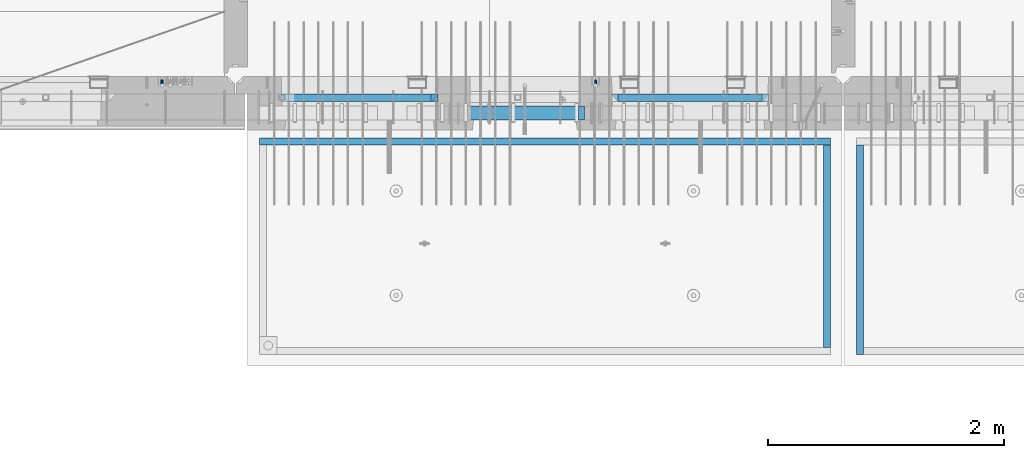
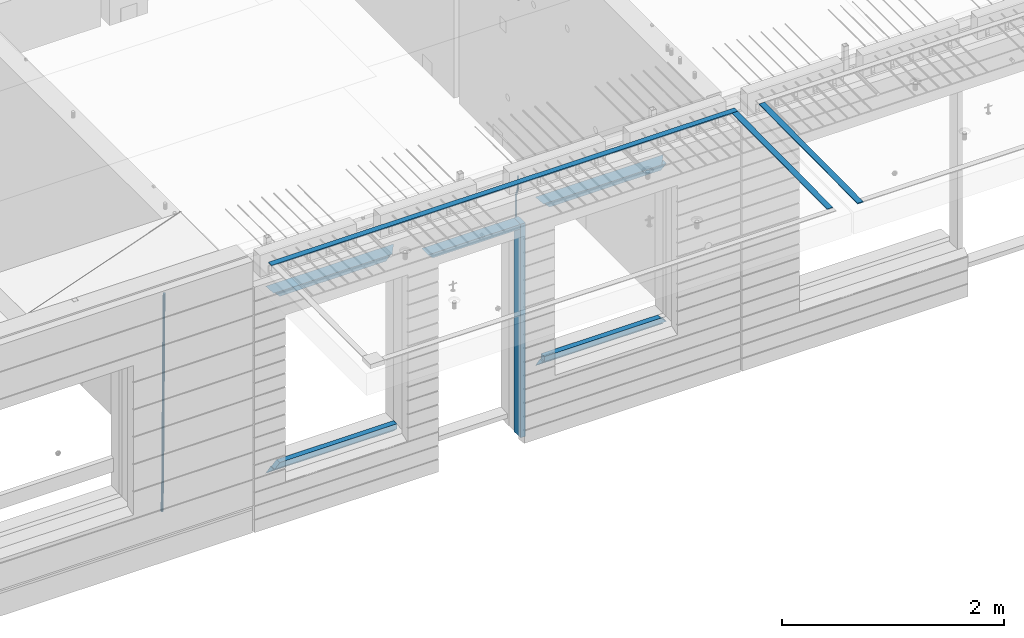
# One storey, part 96 of 350: 15 beams, 4 elements without a shape of their own.
"""IFC2X3 building model written with IfcOpenShell, lengths in millimetres."""

from ifc_helpers import new_model, si_unit, frame, origin_with_axes, place, context, subcontext, project, spatial, faceted_brep, material, type_object, element, aggregate, save


model = new_model("IFC2X3")

# Units and contexts
model_context = context("Model", 3, precision=1e-05, world=origin_with_axes())
body_context = subcontext(model_context, "Body", "Model", "MODEL_VIEW")
ifc_project = project(units=[si_unit("LENGTHUNIT", "METRE", prefix="MILLI"), si_unit("AREAUNIT", "SQUARE_METRE"), si_unit("VOLUMEUNIT", "CUBIC_METRE"), si_unit("MASSUNIT", "GRAM", prefix="KILO"), si_unit("TIMEUNIT", "SECOND"), si_unit("PLANEANGLEUNIT", "RADIAN"), si_unit("SOLIDANGLEUNIT", "STERADIAN"), si_unit("THERMODYNAMICTEMPERATUREUNIT", "DEGREE_CELSIUS"), si_unit("LUMINOUSINTENSITYUNIT", "LUMEN")], contexts=[model_context])

# Site, building, storey
site_placement = place(None, origin_with_axes())
site = spatial("IfcSite", under=ifc_project, at=site_placement, CompositionType="ELEMENT")
building_placement = place(site_placement, origin_with_axes())
building = spatial("IfcBuilding", under=site, at=building_placement, CompositionType="ELEMENT")
storey_placement = place(building_placement, origin_with_axes())
storey = spatial("IfcBuildingStorey", under=building, at=storey_placement, Name="2", CompositionType="ELEMENT", Elevation=0.0)

# Assembly, beam
assembly_1_placement = place(storey_placement, origin_with_axes())
assembly_1 = element("IfcElementAssembly", 1, at=assembly_1_placement, inside=storey, AssemblyPlace="NOTDEFINED", PredefinedType="REINFORCEMENT_UNIT")
ifc_material_1 = material()
beam_type_1 = type_object("IfcBeamType", Name="D20", PredefinedType="NOTDEFINED")
beam_1_placement = place(assembly_1_placement, frame((19710.0073333522, 7925.0, 87407.5000058722), z_axis=(0.000415599999849905, 0.999999913638203, 4.76000000899737e-07), x_axis=(0.0, 0.0, -1.0)))
beam_1 = element("IfcBeam", 2, at=beam_1_placement, type_object=beam_type_1, material=ifc_material_1, Name="JM20", ObjectType="D20", context=body_context, shape_type="Brep", body=[
    faceted_brep([(0.0, -10.0, 0.0), (-4.19531716033816e-08, -7.07106781186667, -7.07106781187031), (113.248091332178, -7.0710684840451, -7.0710678117357), (113.248091314759, -10.0000006713562, -2.51020537689328e-10), (0.0, 0.0, -10.0), (113.248091374131, -6.72178430249915e-07, -9.99999999986903), (4.196772351861e-08, 7.07106781186303, -7.07106781186667), (113.248091416113, 7.07106713968824, -7.07106781173934), (0.0, 10.0, 0.0), (113.248091433488, 9.99999932782521, 1.30967237055302e-10), (4.196772351861e-08, 7.07106781185939, 7.07106781185939), (113.248091416113, 7.0710671396846, 7.071067811994), (0.0, 0.0, 10.0), (113.248091374131, -6.72174792271107e-07, 10.0000000001273), (-4.19531716033816e-08, -7.07106781187031, 7.07106781185939), (113.248091332178, -7.0710684840451, 7.071067811994), (130.699843527167, -7.06993249763036, -4.33745683788584), (128.538066582521, -9.99900540317321, 2.39499413731755), (131.594536475241, 0.00119355250353692, -7.12624594330919), (130.698046432328, 7.07220300913468, -4.33773834422391), (128.535525107087, 10.0009944322555, 2.39459602660281), (126.373748162892, 7.07192152754578, 9.1270470011732), (125.479055214906, 0.000795477419160306, 11.9158361066184), (126.37554525779, -7.07021397921199, 9.12732850753673), (240.336258550378, -7.05529970173666, 30.8729495437874), (238.174481606227, -9.98437260450009, 37.6054005176375), (241.230951498423, 0.0158263482953771, 28.0841604381058), (240.334461455612, 7.0868358050102, 30.8726680369582), (238.171940130502, 10.0156272283348, 37.6050024077231), (236.010163186409, 7.08655432384694, 44.3374533824244), (235.115470238379, 0.0154282738185429, 47.1262424881097), (236.011960281176, -7.05558118289991, 44.3377348892536), (253.461915329972, -7.05444528127919, 32.9289287376414), (253.46191532613, -9.98337746617108, 39.9999965521893), (253.461915339081, 0.0166225284556276, 29.9999965443676), (253.461915348205, 7.08769034247234, 32.9289287273205), (253.461915352003, 10.0166225357716, 39.9999965370152), (253.461915348293, 7.08769035281148, 47.0710643509774), (253.461915339183, 0.0166225430875784, 49.999996544273), (253.46191533003, -7.05444527093641, 47.0710643613093), (1617.47998045172, -7.05444857276962, 32.9289287369675), (1617.47998044467, -9.98338075699212, 39.9999965504549), (1617.47998046874, 0.0166192374708771, 29.9999965449206), (1617.47998048575, 7.08768705096008, 32.9289287291404), (1617.47998049279, 10.0166192430079, 39.9999965393854), (1617.47998048575, 7.08768705878902, 47.071064352871), (1617.47998046874, 0.0166192485448846, 49.9999965449197), (1617.47998045172, -7.05444856494069, 47.0710643606981)], [[[0, 1, 2, 3]], [[1, 4, 5, 2]], [[4, 6, 7, 5]], [[6, 8, 9, 7]], [[8, 10, 11, 9]], [[10, 12, 13, 11]], [[12, 14, 15, 13]], [[14, 0, 3, 15]], [[14, 12, 10, 8, 6, 4, 1, 0]], [[3, 2, 16, 17]], [[2, 5, 18, 16]], [[5, 7, 19, 18]], [[7, 9, 20, 19]], [[9, 11, 21, 20]], [[11, 13, 22, 21]], [[13, 15, 23, 22]], [[15, 3, 17, 23]], [[17, 16, 24, 25]], [[16, 18, 26, 24]], [[18, 19, 27, 26]], [[19, 20, 28, 27]], [[20, 21, 29, 28]], [[21, 22, 30, 29]], [[22, 23, 31, 30]], [[23, 17, 25, 31]], [[25, 24, 32, 33]], [[24, 26, 34, 32]], [[26, 27, 35, 34]], [[27, 28, 36, 35]], [[28, 29, 37, 36]], [[29, 30, 38, 37]], [[30, 31, 39, 38]], [[31, 25, 33, 39]], [[33, 32, 40, 41]], [[32, 34, 42, 40]], [[34, 35, 43, 42]], [[35, 36, 44, 43]], [[36, 37, 45, 44]], [[37, 38, 46, 45]], [[38, 39, 47, 46]], [[39, 33, 41, 47]], [[42, 43, 44, 45, 46, 47, 41, 40]]]),
])

assembly_2_placement = place(storey_placement, origin_with_axes())
assembly_2 = element("IfcElementAssembly", 3, at=assembly_2_placement, inside=storey, AssemblyPlace="NOTDEFINED", PredefinedType="REINFORCEMENT_UNIT")
beam_type_2 = type_object("IfcBeamType", Name="D25", PredefinedType="NOTDEFINED")
beam_2_placement = place(assembly_2_placement, frame((16034.9999999961, 7965.00000227913, 84990.0), z_axis=(0.00020576299992186, -0.999642804629538, -0.0267249099901004), x_axis=(-4.30000201928125e-08, -0.0267249099948059, 0.999642825806181)))
beam_2 = element("IfcBeam", 4, at=beam_2_placement, type_object=beam_type_2, material=ifc_material_1, Name="JM25", ObjectType="D25", context=body_context, shape_type="Brep", body=[
    faceted_brep([(-7.41420080885291e-08, -12.5, -3.63797880709171e-12), (-6.42030499875546e-08, -10.8253175473074, -6.25000000000364), (60.4103898235917, -10.8253175318459, -6.2499999938409), (60.4103898269532, -12.4999999845422, 6.16273609921336e-09), (-3.70782800018787e-08, -6.25000000000364, -10.8253175473074), (60.4103898202884, -6.24999998454587, -10.8253175411446), (-1.45519152283669e-11, -3.63797880709171e-12, -12.5), (60.4103898179019, 1.54577719513327e-08, -12.4999999938373), (3.70637280866504e-08, 6.25, -10.8253175473074), (60.410389817087, 6.25000001545777, -10.825317541141), (6.42030499875546e-08, 10.8253175473001, -6.25000000000364), (60.410389818062, 10.8253175627578, -6.24999999383726), (7.41420080885291e-08, 12.4999999999927, 0.0), (60.4103898205503, 12.5000000154541, 6.16273609921336e-09), (6.42176019027829e-08, 10.8253175473001, 6.24999999999636), (60.4103898238973, 10.8253175627651, 6.2500000061591), (3.70928319171071e-08, 6.24999999999636, 10.8253175473037), (60.4103898272151, 6.25000001546141, 10.8253175534664), (1.45519152283669e-11, -3.63797880709171e-12, 12.4999999999964), (60.4103898296162, 1.54541339725256e-08, 12.5000000061591), (-3.7049176171422e-08, -6.25000000000364, 10.8253175473001), (60.4103898304165, -6.24999998454587, 10.8253175534701), (-6.41884980723262e-08, -10.8253175473074, 6.25), (60.4103898294561, -10.8253175318459, 6.25000000616637), (61.0324985728803, -10.8253175316895, -6.24999999377542), (60.991802792938, -12.4999999843931, 6.22458173893392e-09), (61.0622854283865, -6.24999998437852, -10.8253175410755), (61.0731819955545, 1.5628756955266e-08, -12.4999999937718), (61.0622685480339, 6.25000001562512, -10.8253175410791), (61.032469335245, 10.8253175629216, -6.24999999377178), (60.9917690322181, 12.5000000156033, 6.22458173893392e-09), (60.9510732522613, 10.8253175629034, 6.25000000621731), (60.9212863967696, 6.25000001558874, 10.8253175535247), (60.9103898296162, 1.55814632307738e-08, 12.5000000062137), (60.9213032771368, -6.24999998441126, 10.8253175535174), (60.9511024898966, -10.8253175317113, 6.25000000621731), (61.6545545670233, -10.8253158516927, -6.24189838219536), (61.573166454793, -12.499998414296, 0.00757164385504439), (61.7141257553885, -6.24999822394238, -10.8168280205282), (61.7359179680789, 1.80548886419274e-06, -12.491368569139), (61.7140919992817, 6.25000177601396, -10.8168282403167), (61.6544960997562, 10.8253192428383, -6.2418987628771), (61.5730989426083, 12.5000015856094, 0.0075712042817031), (61.4917108303925, 10.8253190230062, 6.25704123032847), (61.4321396420273, 6.25000139525582, 10.8319708686649), (61.4103474293224, 1.36582457344048e-06, 12.5065114172721), (61.4321733981196, -6.24999860470052, 10.8319710884571), (61.4917692976451, -10.8253160715249, 6.25704161101385), (176.524302641745, -10.8250056210964, -4.74584321979273), (176.442914529529, -12.4996881836996, 1.50362680625403), (176.583873830095, -6.24968799334965, -9.3207728581292), (176.605666042786, 0.000312036081595579, -10.9953134067364), (176.583840074018, 6.25031200660669, -9.32077307791769), (176.524244174492, 10.8256294734347, -4.74584360047811), (176.44284701733, 12.5003118162058, 1.50362636668069), (176.361458905099, 10.8256292535989, 7.75309639272746), (176.301887716749, 6.25031162585219, 12.3280260310676), (176.280095504058, 0.000311596420942806, 14.0025665796711), (176.301921472827, -6.24968837410415, 12.3280262508561), (176.361517372367, -10.8250058409321, 7.75309677341284), (177.085397012124, -10.8250041057399, -4.73853556792164), (176.983633547483, -12.4996867233749, 1.51066909103247), (177.159881729676, -6.24968643771717, -9.31327097355097), (177.187129580227, 0.000313606451527448, -10.987740468332), (177.159839524218, 6.25031356221734, -9.31327130338468), (177.085323910098, 10.8256309887511, -4.73853613920801), (176.983549136537, 12.5003132764905, 1.51066843136869), (176.881785671867, 10.8256306588555, 7.7598730903228), (176.80730095433, 6.25031299082912, 12.3346084959521), (176.780053103794, 0.000312946667690994, 14.0090779907332), (176.807343159802, -6.2496870091054, 12.3346088257895), (176.881858773908, -10.8250044356355, 7.7598736616128), (177.646431799818, -10.8250018318176, -4.72756919822132), (177.524295146417, -12.4996845320202, 1.52123723245313), (177.735828462886, -6.24968410334986, -9.30201312475765), (177.768531371941, 0.00031596292683389, -10.9763759912421), (177.735777808921, 6.25031589654827, -9.30201361973741), (177.646344064575, 10.8256332626152, -4.72757005553649), (177.524193838486, 12.5003154677688, 1.52123624250817), (177.402057185071, 10.8256327675663, 7.77004267317898), (177.312660521988, 6.2503150390985, 12.3444865997226), (177.279957612933, 0.00031497282179771, 14.0188494661961), (177.312711175953, -6.24968496079964, 12.3444870946951), (177.402144920314, -10.8250023268702, 7.77004353049415), (299.377443161706, -10.8245084454466, -2.34813158632096), (299.255306508276, -12.4991911456491, 3.90067484435349), (299.466839824803, -6.24919071697514, -6.92257551286093), (299.499542733873, 0.0008093492979242, -8.59693837933446), (299.466789170867, 6.250809282923, -6.92257600783341), (299.377355426492, 10.8261266489935, -2.34813244364341), (299.255205200388, 12.5008088541435, 3.90067385440125), (299.133068546944, 10.826126153941, 10.1494802850757), (299.043671883861, 6.25080842546959, 14.7239242116229), (299.010968974762, 0.000808359200163977, 16.3982870780892), (299.043722537797, -6.24919157442127, 14.7239247065918), (299.133156282158, -10.8245089404954, 10.1494811423981), (299.98561436501, -10.8245059804758, -2.33624385599614), (299.97179243555, -12.4991882411778, 3.91467976726199), (299.995742293278, -6.24918857328521, -6.91223722345239), (299.999447243041, 0.000811375455668895, -8.58716690387519), (299.995736475976, 6.25081142679483, -6.91223684201032), (299.985604289133, 10.8261291142808, -2.33624319533556), (299.971750386685, 12.5008117588586, 3.91467993563856), (299.957928457196, 10.8261294971744, 10.1656035610831), (299.947800528913, 6.25081208998381, 14.7415969285394), (299.944095579151, 0.00081214124293183, 16.4165266089549), (299.947806346216, -6.24918791008895, 14.7415965471009), (299.957938533058, -10.8245055975785, 10.1656029004225), (300.593832239858, -10.8245078794353, -2.34543881707941), (300.688302931099, -12.4991904788549, 3.90384712594823), (300.524685350189, -6.24919022474205, -6.92023371784308), (300.499390115292, 0.000809814544481924, -8.59472497713432), (300.524724372954, 6.25080977519247, -6.92023401429469), (300.593899829313, 10.8261272150703, -2.34543933054374), (300.688380976673, 12.5008095210287, 3.90384653304136), (300.782851667915, 10.8261269216127, 10.1531324760799), (300.851998557599, 6.25080926691589, 14.7279273768363), (300.877293792495, 0.000809227632998955, 16.4024186361276), (300.851959534804, -6.24919073302226, 14.7279276732806), (300.782784078474, -10.8245081728965, 10.153132989537), (2293.32930409742, -10.8307295605009, -32.4713622331001), (2293.42377478865, -12.5054121599169, -26.2220762900724), (2293.26015720774, -6.2554119058077, -37.0461571338565), (2293.23486197284, -0.00541186651753378, -38.7206483931477), (2293.26019623051, 6.24458809413409, -37.0461574303008), (2293.32937168686, 10.8199055340046, -32.4713627465644), (2293.42385283421, 12.4945878399631, -26.2220768829684), (2293.51832352545, 10.8199052405434, -19.972790939948), (2293.58747041514, 6.24458758585388, -15.3979960391844), (2293.61276565003, -0.00541245343265473, -13.7235047798931), (2293.58743139236, -6.25541241408428, -15.3979957427327), (2293.51825593603, -10.8307298539585, -19.9727904264691), (2294.0420846676, -10.8307317859326, -32.4821379598216), (2294.03681932652, -12.5054140739521, -26.2313442200393), (2294.06778164886, -6.2554144273563, -37.0583666982457), (2294.10702478497, -0.00541458957013674, -38.7338336404937), (2294.14929890928, 6.24458531819619, -37.0595987724118), (2294.18327670435, 10.8199028679592, -32.4842719748667), (2294.1998538474, 12.4945854171456, -26.2338083683717), (2294.19458850632, 10.819903129126, -19.9830146285858), (2294.16889152506, 6.24458577054975, -15.4067858901581), (2294.12964838895, -0.0054140672327776, -13.7313189479173), (2294.08737426462, -6.2554139749991, -15.4055538159919), (2294.05339646956, -10.8307315247621, -19.9808806135297), (2294.75482297382, -10.84002603931, -32.4726521173216), (2294.64982751427, -12.513407826169, -26.2231856868602), (2294.87535820232, -6.26594539088183, -37.0476186524102), (2294.97913588268, -0.0167870967634371, -38.7222267036377), (2295.0383488692, 6.23299192477134, -37.0477663960555), (2295.03713108998, 10.8087684320271, -32.4729080168181), (2294.97580884799, 12.4844668051373, -26.2234811741473), (2294.87081338844, 10.8110850182784, -19.9740147436787), (2294.7502781599, 6.23700436985018, -15.3990482086047), (2294.64650047956, -0.0121539242718427, -13.7244401573698), (2294.58728749304, -6.26193294580662, -15.3989004649666), (2294.58850527227, -10.8377094530588, -19.9737588441894), (2316.44667268227, -11.1228921988077, -32.1839550346631), (2316.34167722271, -12.7962739856739, -25.9344886042054), (2316.56720791078, -6.54881155039038, -36.7589215697517), (2316.67098559113, -0.299653256264719, -38.4335296209792), (2316.73019857766, 5.95012576527006, -36.759069313397), (2316.72898079845, 10.5259022725259, -32.1842109341669), (2316.66765855643, 12.2016006456361, -25.9347840914961), (2316.56266309689, 10.5282188587698, -19.6853176610275), (2316.44212786836, 5.95413821035254, -15.1103511259389), (2316.33835018802, -0.295020083769487, -13.4357430747186), (2316.27913720149, -6.54479910530426, -15.1102033823008), (2316.28035498071, -11.1205756125637, -19.685061761531), (2317.13234804722, -11.1318335458927, -32.1748293731798), (2317.04181141085, -12.8054038787741, -25.9251705100723), (2317.2154741603, -6.5572650749491, -36.7502937866229), (2317.26891617525, -0.307450393454928, -38.4255717558117), (2317.27835434731, 5.94297770185585, -36.7517739018112), (2317.24125972588, 10.5192220504723, -32.1773930078925), (2317.16757178486, 12.1950816748285, -25.9281307404563), (2317.0770351485, 10.5215113419545, -19.6784718773561), (2316.99390903539, 5.94694287101083, -15.1030074639057), (2316.94046702047, -0.302871810494253, -13.4277294947169), (2316.9310288484, -6.55329990579412, -15.1015273487101), (2316.96812346982, -11.1295442544142, -19.6759082426288), (2317.81808136747, -11.1298054502913, -32.1659056455355), (2317.74200467508, -12.803315894289, -25.9160547315114), (2317.86379538118, -6.55536082026447, -36.7418676070083), (2317.8668976831, -0.305700748642266, -38.417815303761), (2317.82655701396, 5.94458339541234, -36.7446799039099), (2317.75358262347, 10.5207330230332, -32.1707766866384), (2317.66752794063, 12.1965725370646, -25.9216793252963), (2317.59145124823, 10.5230620930706, -19.6718284112721), (2317.54573723453, 5.94861746304377, -15.0958664497994), (2317.54263493262, -0.301042608574789, -13.4199187530394), (2317.58297560175, -6.55132675263303, -15.0930541529051), (2317.65594999224, -11.1274763802539, -19.6669573701693), (2417.81884292323, -10.831603083323, -30.8687911350135), (2417.74276623082, -12.505113527317, -24.618940220982), (2417.86455693691, -6.25715845329614, -35.4447530964935), (2417.86765923884, -0.00749838167394046, -37.1207007932499), (2417.82731856969, 6.24278576237703, -35.4475653933878), (2417.75434417921, 10.8189353900088, -30.8736621761236), (2417.66828949639, 12.494774904033, -24.6245648147851), (2417.59221280397, 10.8212644600353, -18.3747139007501), (2417.54649879028, 6.2468198300121, -13.79875193927), (2417.54339648837, -0.00284024161010166, -12.1228042425173), (2417.5837371575, -6.25312438566107, -13.795939642383), (2417.65671154798, -10.8292740132893, -18.3698428596399)], [[[0, 1, 2, 3]], [[1, 4, 5, 2]], [[4, 6, 7, 5]], [[6, 8, 9, 7]], [[8, 10, 11, 9]], [[10, 12, 13, 11]], [[12, 14, 15, 13]], [[14, 16, 17, 15]], [[16, 18, 19, 17]], [[18, 20, 21, 19]], [[20, 22, 23, 21]], [[22, 0, 3, 23]], [[22, 20, 18, 16, 14, 12, 10, 8, 6, 4, 1, 0]], [[3, 2, 24, 25]], [[2, 5, 26, 24]], [[5, 7, 27, 26]], [[7, 9, 28, 27]], [[9, 11, 29, 28]], [[11, 13, 30, 29]], [[13, 15, 31, 30]], [[15, 17, 32, 31]], [[17, 19, 33, 32]], [[19, 21, 34, 33]], [[21, 23, 35, 34]], [[23, 3, 25, 35]], [[25, 24, 36, 37]], [[24, 26, 38, 36]], [[26, 27, 39, 38]], [[27, 28, 40, 39]], [[28, 29, 41, 40]], [[29, 30, 42, 41]], [[30, 31, 43, 42]], [[31, 32, 44, 43]], [[32, 33, 45, 44]], [[33, 34, 46, 45]], [[34, 35, 47, 46]], [[35, 25, 37, 47]], [[37, 36, 48, 49]], [[36, 38, 50, 48]], [[38, 39, 51, 50]], [[39, 40, 52, 51]], [[40, 41, 53, 52]], [[41, 42, 54, 53]], [[42, 43, 55, 54]], [[43, 44, 56, 55]], [[44, 45, 57, 56]], [[45, 46, 58, 57]], [[46, 47, 59, 58]], [[47, 37, 49, 59]], [[49, 48, 60, 61]], [[48, 50, 62, 60]], [[50, 51, 63, 62]], [[51, 52, 64, 63]], [[52, 53, 65, 64]], [[53, 54, 66, 65]], [[54, 55, 67, 66]], [[55, 56, 68, 67]], [[56, 57, 69, 68]], [[57, 58, 70, 69]], [[58, 59, 71, 70]], [[59, 49, 61, 71]], [[61, 60, 72, 73]], [[60, 62, 74, 72]], [[62, 63, 75, 74]], [[63, 64, 76, 75]], [[64, 65, 77, 76]], [[65, 66, 78, 77]], [[66, 67, 79, 78]], [[67, 68, 80, 79]], [[68, 69, 81, 80]], [[69, 70, 82, 81]], [[70, 71, 83, 82]], [[71, 61, 73, 83]], [[73, 72, 84, 85]], [[72, 74, 86, 84]], [[74, 75, 87, 86]], [[75, 76, 88, 87]], [[76, 77, 89, 88]], [[77, 78, 90, 89]], [[78, 79, 91, 90]], [[79, 80, 92, 91]], [[80, 81, 93, 92]], [[81, 82, 94, 93]], [[82, 83, 95, 94]], [[83, 73, 85, 95]], [[85, 84, 96, 97]], [[84, 86, 98, 96]], [[86, 87, 99, 98]], [[87, 88, 100, 99]], [[88, 89, 101, 100]], [[89, 90, 102, 101]], [[90, 91, 103, 102]], [[91, 92, 104, 103]], [[92, 93, 105, 104]], [[93, 94, 106, 105]], [[94, 95, 107, 106]], [[95, 85, 97, 107]], [[97, 96, 108, 109]], [[96, 98, 110, 108]], [[98, 99, 111, 110]], [[99, 100, 112, 111]], [[100, 101, 113, 112]], [[101, 102, 114, 113]], [[102, 103, 115, 114]], [[103, 104, 116, 115]], [[104, 105, 117, 116]], [[105, 106, 118, 117]], [[106, 107, 119, 118]], [[107, 97, 109, 119]], [[109, 108, 120, 121]], [[108, 110, 122, 120]], [[110, 111, 123, 122]], [[111, 112, 124, 123]], [[112, 113, 125, 124]], [[113, 114, 126, 125]], [[114, 115, 127, 126]], [[115, 116, 128, 127]], [[116, 117, 129, 128]], [[117, 118, 130, 129]], [[118, 119, 131, 130]], [[119, 109, 121, 131]], [[121, 120, 132, 133]], [[120, 122, 134, 132]], [[122, 123, 135, 134]], [[123, 124, 136, 135]], [[124, 125, 137, 136]], [[125, 126, 138, 137]], [[126, 127, 139, 138]], [[127, 128, 140, 139]], [[128, 129, 141, 140]], [[129, 130, 142, 141]], [[130, 131, 143, 142]], [[131, 121, 133, 143]], [[133, 132, 144, 145]], [[132, 134, 146, 144]], [[134, 135, 147, 146]], [[135, 136, 148, 147]], [[136, 137, 149, 148]], [[137, 138, 150, 149]], [[138, 139, 151, 150]], [[139, 140, 152, 151]], [[140, 141, 153, 152]], [[141, 142, 154, 153]], [[142, 143, 155, 154]], [[143, 133, 145, 155]], [[145, 144, 156, 157]], [[144, 146, 158, 156]], [[146, 147, 159, 158]], [[147, 148, 160, 159]], [[148, 149, 161, 160]], [[149, 150, 162, 161]], [[150, 151, 163, 162]], [[151, 152, 164, 163]], [[152, 153, 165, 164]], [[153, 154, 166, 165]], [[154, 155, 167, 166]], [[155, 145, 157, 167]], [[157, 156, 168, 169]], [[156, 158, 170, 168]], [[158, 159, 171, 170]], [[159, 160, 172, 171]], [[160, 161, 173, 172]], [[161, 162, 174, 173]], [[162, 163, 175, 174]], [[163, 164, 176, 175]], [[164, 165, 177, 176]], [[165, 166, 178, 177]], [[166, 167, 179, 178]], [[167, 157, 169, 179]], [[169, 168, 180, 181]], [[168, 170, 182, 180]], [[170, 171, 183, 182]], [[171, 172, 184, 183]], [[172, 173, 185, 184]], [[173, 174, 186, 185]], [[174, 175, 187, 186]], [[175, 176, 188, 187]], [[176, 177, 189, 188]], [[177, 178, 190, 189]], [[178, 179, 191, 190]], [[179, 169, 181, 191]], [[181, 180, 192, 193]], [[180, 182, 194, 192]], [[182, 183, 195, 194]], [[183, 184, 196, 195]], [[184, 185, 197, 196]], [[185, 186, 198, 197]], [[186, 187, 199, 198]], [[187, 188, 200, 199]], [[188, 189, 201, 200]], [[189, 190, 202, 201]], [[190, 191, 203, 202]], [[191, 181, 193, 203]], [[194, 195, 196, 197, 198, 199, 200, 201, 202, 203, 193, 192]]]),
])
aggregate(assembly_2, [beam_2])

assembly_3_placement = place(storey_placement, origin_with_axes())
assembly_3 = element("IfcElementAssembly", 5, at=assembly_3_placement, inside=storey, AssemblyPlace="NOTDEFINED", PredefinedType="REINFORCEMENT_UNIT")
ifc_material_2 = material(Name="CONCRETE/Concrete_Undefined")
beam_type_3 = type_object("IfcBeamType", PredefinedType="NOTDEFINED")
beam_3_placement = place(assembly_3_placement, frame((21949.9413897781, 7420.05314849477, 87725.6636561746), z_axis=(2.93000000986506e-07, -0.00901322400064496, 0.999959380071525), x_axis=(3.25389999851993e-05, -0.999959379542196, -0.00901322399586982)))
beam_3 = element("IfcBeam", 6, at=beam_3_placement, type_object=beam_type_3, material=ifc_material_2, context=body_context, shape_type="Brep", body=[
    faceted_brep([(2.5465851649642e-11, 29.9999999999982, -4.99999999998545), (-2.91038304567337e-11, 29.9999999999982, 5.0), (1775.16788460852, 30.0000000000036, 5.0), (1775.16788460861, 30.0000000000036, -4.99999999998545), (-2.5465851649642e-11, -30.0000000000018, 5.0), (1775.16788460852, -29.9999999999927, 5.0), (2.72848410531878e-11, -30.0000000000018, -4.99999999998545), (1775.16788460861, -29.9999999999927, -4.99999999998545)], [[[0, 1, 2, 3]], [[1, 4, 5, 2]], [[4, 6, 7, 5]], [[6, 0, 3, 7]], [[5, 7, 3, 2]], [[6, 4, 1, 0]]]),
])
aggregate(assembly_3, [beam_3])

# Assembly, beams
assembly_4_placement = place(storey_placement, origin_with_axes())
assembly_4 = element("IfcElementAssembly", 7, at=assembly_4_placement, inside=storey, AssemblyPlace="NOTDEFINED", PredefinedType="REINFORCEMENT_UNIT")
beam_4_placement = place(assembly_4_placement, frame((21670.0013901233, 7419.93998011425, 87723.2790373904), z_axis=(-5.99999839176643e-09, -0.0089070149978186, 0.99996033175513), x_axis=(-7.26999998800451e-07, -0.999960331754865, -0.00890701499781462)))
beam_4 = element("IfcBeam", 8, at=beam_4_placement, type_object=beam_type_3, material=ifc_material_2, context=body_context, shape_type="Brep", body=[
    faceted_brep([(2.5465851649642e-11, 29.9999999999982, -4.99999999998545), (-2.91038304567337e-11, 29.9999999999982, 5.0), (1714.98205429674, 30.0, 5.00000000001455), (1714.98205429674, 30.0000000000036, -4.99999999998545), (-2.5465851649642e-11, -30.0000000000018, 5.0), (1714.98205429674, -30.0, 5.00000000001455), (2.72848410531878e-11, -30.0000000000018, -4.99999999998545), (1714.98205429674, -29.9999999999964, -4.99999999998545)], [[[0, 1, 2, 3]], [[1, 4, 5, 2]], [[4, 6, 7, 5]], [[6, 0, 3, 7]], [[5, 7, 3, 2]], [[6, 4, 1, 0]]]),
])
beam_5_placement = place(assembly_4_placement, frame((21700.0027302922, 7449.93184428734, 87723.6588442717), z_axis=(0.0, 0.0, 1.0), x_axis=(-0.999999999888168, 1.49249999983396e-05, 9.53000001204034e-07)))
beam_5 = element("IfcBeam", 9, at=beam_5_placement, type_object=beam_type_3, material=ifc_material_2, context=body_context, shape_type="Brep", body=[
    faceted_brep([(2.5465851649642e-11, 29.9999999999982, -4.99999999998545), (-2.91038304567337e-11, 29.9999999999982, 5.0), (4840.00999799337, 29.9999999999991, 5.0), (4840.00999799337, 29.9999999999982, -5.00000000001455), (-2.5465851649642e-11, -30.0000000000018, 5.0), (4840.00999799337, -30.0000000000009, 5.0), (2.72848410531878e-11, -30.0000000000018, -4.99999999998545), (4840.00999799337, -30.0000000000009, -5.0)], [[[0, 1, 2, 3]], [[1, 4, 5, 2]], [[4, 6, 7, 5]], [[6, 0, 3, 7]], [[5, 7, 3, 2]], [[6, 4, 1, 0]]]),
])
aggregate(assembly_4, [beam_4, beam_5])

# Beam
ifc_material_3 = material(Name="CONCRETE/C35/45")
beam_type_4 = type_object("IfcBeamType", PredefinedType="NOTDEFINED")
beam_6_placement = place(assembly_1_placement, frame((17044.9994828029, 7820.0, 87145.0), z_axis=(0.0, 0.0, -1.0), x_axis=(1.0, 0.0, 0.0)))
beam_6 = element("IfcBeam", 10, at=beam_6_placement, type_object=beam_type_4, material=ifc_material_3, Name="SK", context=body_context, shape_type="Brep", body=[
    faceted_brep([(0.0, -30.0, -30.0), (49.817662327685, -30.0, 30.0), (49.817662327685, 30.0, 30.0), (1330.00114440918, -30.0, -30.0), (1280.18348208149, -30.0, 30.0), (1280.18348208149, 30.0, 30.0)], [[[0, 1, 2]], [[1, 0, 3, 4]], [[2, 1, 4, 5]], [[0, 2, 5, 3]], [[4, 3, 5]]]),
])

beam_7_placement = place(assembly_1_placement, frame((17104.9994828029, 7820.0, 87085.0), z_axis=(0.0, 0.0, -1.0), x_axis=(1.0, 0.0, 0.0)))
beam_7 = element("IfcBeam", 11, at=beam_7_placement, type_object=beam_type_4, material=ifc_material_3, Name="SK", context=body_context, shape_type="Brep", body=[
    faceted_brep([(0.0, -30.0, -30.0), (53.0959879499314, -30.0, 24.0540540540678), (54.6888675884184, 30.0, 25.6756756756804), (0.0, 30.0, -30.0), (1210.00114440918, -30.0, -30.0), (1156.90515645927, -30.0, 24.0540540540678), (1155.31227682078, 30.0, 25.6756756756804), (1210.00114440918, 30.0, -30.0)], [[[0, 1, 2, 3]], [[1, 0, 4, 5]], [[2, 1, 5, 6]], [[3, 2, 6, 7]], [[0, 3, 7, 4]], [[6, 5, 4, 7]]]),
])

beam_8_placement = place(assembly_1_placement, frame((18375.0006272121, 7820.0, 85150.0), z_axis=(0.0, 0.0, 1.0), x_axis=(-1.0, 3.00000001838171e-08, 0.0)))
beam_8 = element("IfcBeam", 12, at=beam_8_placement, type_object=beam_type_4, material=ifc_material_3, Name="SK", context=body_context, shape_type="Brep", body=[
    faceted_brep([(0.0, -30.0, 30.0), (-5.28234522789717e-09, 30.0, 30.0), (0.0, -30.0, -30.0), (1280.18348208149, -30.0, 30.0), (1280.18348208149, 30.0, 30.0), (1330.00114440918, -30.0, -30.0)], [[[0, 1, 2]], [[1, 0, 3, 4]], [[2, 1, 4, 5]], [[0, 2, 5, 3]], [[3, 5, 4]]]),
])

beam_9_placement = place(assembly_1_placement, frame((18375.0006272121, 7820.0, 85210.0), z_axis=(0.0, 0.0, 1.0), x_axis=(-1.0, 3.00000001838171e-08, 0.0)))
beam_9 = element("IfcBeam", 13, at=beam_9_placement, type_object=beam_type_4, material=ifc_material_3, Name="SK", context=body_context, shape_type="Brep", body=[
    faceted_brep([(0.0, -30.0, -30.0), (0.0, -30.0, 30.0), (-5.28234522789717e-09, 30.0, 30.0), (0.0, 30.0, -30.0), (4.05405405405327, -30.0, 30.0), (5.67567567567312, 30.0, 30.0), (4.05405405404963, -30.0, 24.0540540540533), (5.67567567567312, 30.0, 25.6756756756804), (1215.31227682077, 30.0, 25.6756756756804), (1270.00114440918, 30.0, -30.0), (1270.00114440918, -30.0, -30.0), (1216.90515645926, -30.0, 24.0540540540678)], [[[0, 1, 2, 3]], [[2, 1, 4, 5]], [[4, 6, 7, 5]], [[3, 2, 5, 7, 8, 9]], [[0, 3, 9, 10]], [[6, 4, 1, 0, 10, 11]], [[7, 6, 11, 8]], [[10, 9, 8, 11]]]),
])

beam_10_placement = place(assembly_1_placement, frame((19845.0006272121, 7820.0, 87145.0), z_axis=(0.0, 0.0, -1.0), x_axis=(1.0, 0.0, 0.0)))
beam_10 = element("IfcBeam", 14, at=beam_10_placement, type_object=beam_type_4, material=ifc_material_3, Name="SK", context=body_context, shape_type="Brep", body=[
    faceted_brep([(0.0, -30.0, -30.0), (49.817662327685, -30.0, 30.0), (49.817662327685, 30.0, 30.0), (1329.99923706055, -30.0, -30.0), (1280.18157473286, -30.0, 30.0), (1280.18157473286, 30.0, 30.0)], [[[0, 1, 2]], [[1, 0, 3, 4]], [[2, 1, 4, 5]], [[0, 2, 5, 3]], [[4, 3, 5]]]),
])

beam_11_placement = place(assembly_1_placement, frame((19905.0006272121, 7820.0, 87085.0), z_axis=(0.0, 0.0, -1.0), x_axis=(1.0, 0.0, 0.0)))
beam_11 = element("IfcBeam", 15, at=beam_11_placement, type_object=beam_type_4, material=ifc_material_3, Name="SK", context=body_context, shape_type="Brep", body=[
    faceted_brep([(0.0, -30.0, -30.0), (53.0959879499314, -30.0, 24.0540540540678), (54.6888675884184, 30.0, 25.6756756756804), (0.0, 30.0, -30.0), (1269.99923706055, -30.0, -30.0), (1211.91971158142, -30.0, 24.0540540540533), (1210.17732581704, 30.0, 25.6756756756804), (1269.99923706055, 30.0, -30.0)], [[[0, 1, 2, 3]], [[1, 0, 4, 5]], [[2, 1, 5, 6]], [[3, 2, 6, 7]], [[0, 3, 7, 4]], [[6, 5, 4, 7]]]),
])

beam_12_placement = place(assembly_1_placement, frame((21174.9998642727, 7820.0, 85350.0), z_axis=(0.0, 0.0, 1.0), x_axis=(-1.0, 3.00000001838171e-08, 0.0)))
beam_12 = element("IfcBeam", 16, at=beam_12_placement, type_object=beam_type_4, material=ifc_material_3, Name="SK", context=body_context, shape_type="Brep", body=[
    faceted_brep([(1280.18157473286, -30.0, 30.0), (1329.99923706055, -30.0, -30.0), (1280.18157473286, 30.0, 30.0), (0.0, -30.0, -30.0), (49.817662327685, 30.0, 30.0), (49.817662327685, -30.0, 30.0)], [[[0, 1, 2]], [[3, 4, 2, 1]], [[4, 5, 0, 2]], [[5, 3, 1, 0]], [[3, 5, 4]]]),
])

beam_13_placement = place(assembly_1_placement, frame((21174.9998642727, 7820.0, 85410.0), z_axis=(0.0, 0.0, 1.0), x_axis=(-1.0, 3.00000001838171e-08, 0.0)))
beam_13 = element("IfcBeam", 17, at=beam_13_placement, type_object=beam_type_4, material=ifc_material_3, Name="SK", context=body_context, shape_type="Brep", body=[
    faceted_brep([(1269.99923706055, -30.0, -30.0), (1269.99923706055, 30.0, -30.0), (1269.99923706055, 30.0, 25.6756756756804), (1269.99923706055, -30.0, 24.0540540540678), (0.0, -30.0, -30.0), (0.0, 30.0, -30.0), (59.8219112435072, 30.0, 25.6756756756804), (58.0795254791192, -30.0, 24.0540540540533)], [[[0, 1, 2, 3]], [[4, 5, 1, 0]], [[2, 1, 5, 6]], [[3, 2, 6, 7]], [[0, 3, 7, 4]], [[6, 5, 4, 7]]]),
])

ifc_material_4 = material(Name="TIMBER")
beam_type_5 = type_object("IfcBeamType", Name="50X120", PredefinedType="NOTDEFINED")
beam_14_placement = place(assembly_1_placement, frame((18604.9998642727, 7690.0, 87080.0), z_axis=(0.0, 0.0, -1.0), x_axis=(1.0, 0.0, 0.0)))
beam_14 = element("IfcBeam", 18, at=beam_14_placement, type_object=beam_type_5, material=ifc_material_4, ObjectType="50X120", context=body_context, shape_type="Brep", body=[
    faceted_brep([(1009.99961853027, -60.0, 25.0), (1009.99961853027, -60.0, -25.0), (1009.99961853027, 60.0, -25.0), (1009.99961853027, 60.0, 25.0), (50.0000000000036, -60.0, 25.0), (0.0, -60.0, -25.0), (0.0, 60.0, -25.0), (50.0000000000036, 60.0, 25.0)], [[[0, 1, 2, 3]], [[1, 0, 4, 5]], [[2, 1, 5, 6]], [[3, 2, 6, 7]], [[0, 3, 7, 4]], [[6, 5, 4, 7]]]),
])

beam_15_placement = place(assembly_1_placement, frame((19589.9994828029, 7690.0, 87105.0), z_axis=(-1.0, 3.00000001838171e-08, 0.0), x_axis=(0.0, 0.0, -1.0)))
beam_15 = element("IfcBeam", 19, at=beam_15_placement, type_object=beam_type_5, material=ifc_material_4, ObjectType="50X120", context=body_context, shape_type="Brep", body=[
    faceted_brep([(0.0, 60.0, -25.0), (0.0, 60.0, 25.0), (2345.0, 60.0, 25.0), (2345.0, 60.0, -25.0), (0.0, -60.0, 25.0), (2345.0, -60.0, 25.0), (0.0, -60.0, -25.0), (2345.0, -60.0, -25.0)], [[[0, 1, 2, 3]], [[1, 4, 5, 2]], [[4, 6, 7, 5]], [[6, 0, 3, 7]], [[5, 7, 3, 2]], [[6, 4, 1, 0]]]),
])

aggregate(assembly_1, [beam_14, beam_15, beam_1, beam_6, beam_7, beam_8, beam_9, beam_10, beam_11, beam_12, beam_13])

save(model, "model.ifc")
